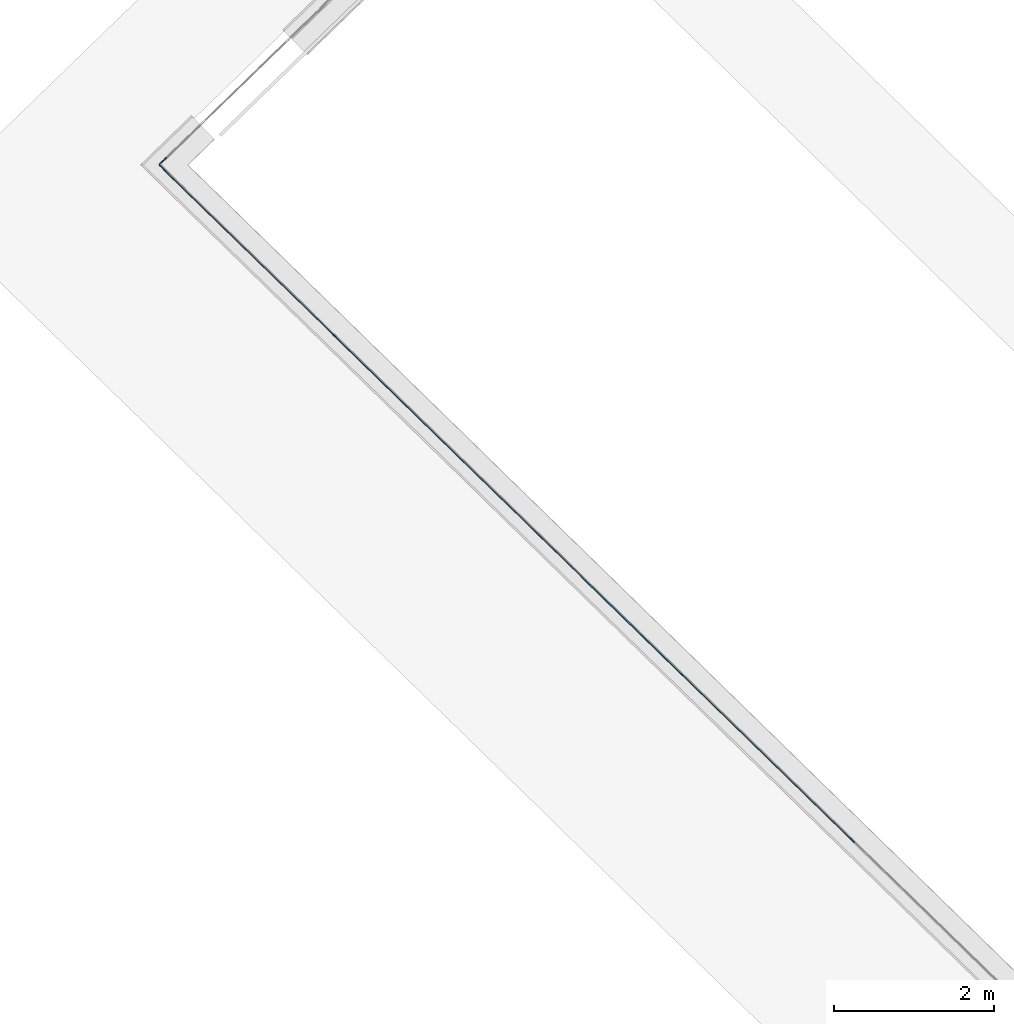
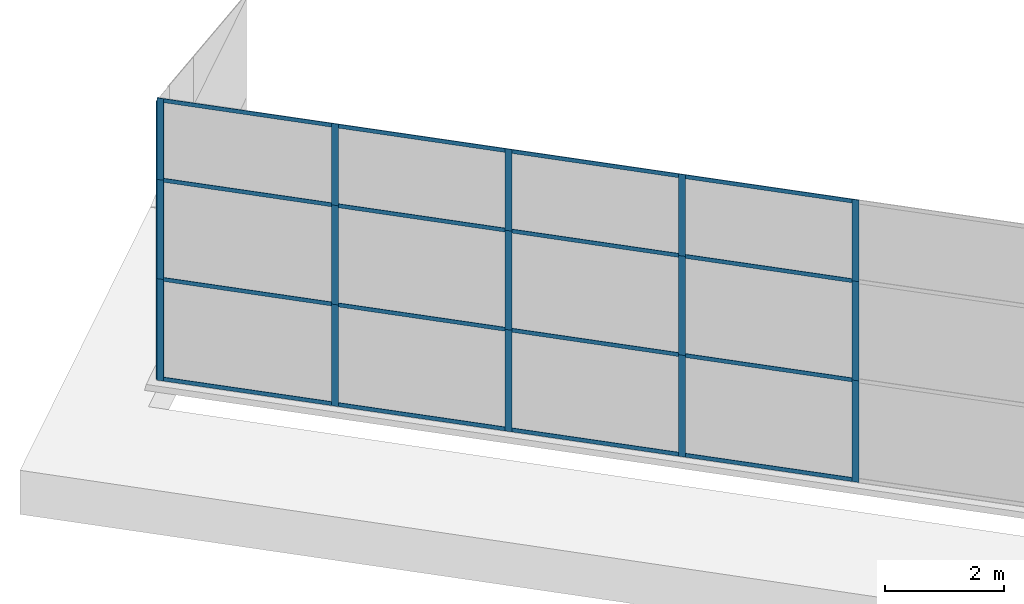
# One storey, part 5 of 13: 34 members, 2 elements without a shape of their own.
"""IFC4 building model written with IfcOpenShell, lengths in metres."""

from ifc_helpers import new_model, entity, si_unit, converted_unit, direction, frame, origin, place, context, subcontext, project, spatial, indexed_curve, outline, extrude, source, transform, mapped, material, type_object, type_shapes, element, aggregate, save


model = new_model("IFC4")

# Units and contexts
model_context = context("Model", 3, precision=1e-05, world=origin(), true_north=direction((6.123233995736766e-17, 1.0)))
body_context = subcontext(model_context, "Body", "Model", "MODEL_VIEW")
ifc_project = project(units=[si_unit("LENGTHUNIT", "METRE"), si_unit("AREAUNIT", "SQUARE_METRE"), si_unit("VOLUMEUNIT", "CUBIC_METRE"), converted_unit("PLANEANGLEUNIT", "DEGREE", entity("IfcPlaneAngleMeasure", 0.017453292519943278), si_unit("PLANEANGLEUNIT", "RADIAN"), dimensions=[0, 0, 0, 0, 0, 0, 0])], contexts=[model_context])

# Site, building, storey
site_placement = place(None, frame((0.0, 0.0, 0.0), z_axis=(0.0, 0.0, 1.0), x_axis=(0.7160934825303189, -0.6980043870045516, 0.0)))
site = spatial("IfcSite", under=ifc_project, at=site_placement, CompositionType="ELEMENT")
building_placement = place(site_placement, origin())
building = spatial("IfcBuilding", under=site, at=building_placement, CompositionType="ELEMENT")
storey_placement = place(building_placement, frame((0.0, 0.0, -7.0)))
storey = spatial("IfcBuildingStorey", under=building, at=storey_placement, Name="-7.00 m", CompositionType="ELEMENT", Elevation=-7.000000000000001)

# Curtain wall, members
curtain_wall_type_1 = type_object("IfcCurtainWallType", Name="Facciata continua:Vetrata_2", PredefinedType="NOTDEFINED")
curtain_wall_1_placement = place(storey_placement, frame((0.0, 0.0, 7.0)))
curtain_wall_1 = element("IfcCurtainWall", 1, at=curtain_wall_1_placement, inside=storey, type_object=curtain_wall_type_1, Name="Facciata continua:Vetrata_2", ObjectType="Facciata continua:Vetrata_2", PredefinedType="NOTDEFINED")
ifc_material = material(Name="Acciaio", Category="Metallo")
member_type_1 = type_object("IfcMemberType", Name="Montante rettangolare:Montante rettangolare 2", PredefinedType="MULLION", material=ifc_material)
shared_shape_1 = source(origin(), body_context, "Body", "SweptSolid", [
    extrude(outline(indexed_curve([(-0.04, -0.004999999999999997), (0.04, -0.004999999999999997), (0.04, 0.004999999999999997), (-0.04, 0.004999999999999997), (-0.04, -0.004999999999999997)], self_intersect=False)), frame((-0.04, 0.009999999999999993, -2.8811750164301526), z_axis=(0.0, 0.0, 1.0), x_axis=(-1.0, 0.0, 0.0)), (0.0, 0.0, 1.0), 2.881175016430152),
])
type_shapes(member_type_1, [shared_shape_1])
member_1_placement = place(curtain_wall_1_placement, frame((-21.789785339440044, -6.977854376535793, -1.1600000000000001), z_axis=(1.0, 0.0, 0.0), x_axis=(0.0, 0.0, 1.0)))
member_1 = element("IfcMember", 2, at=member_1_placement, type_object=member_type_1, material=ifc_material, Name="Montante rettangolare:Montante rettangolare 2", ObjectType="Montante rettangolare:Montante rettangolare 2", PredefinedType="MULLION", context=body_context, shape_type="MappedRepresentation", body=[
    mapped(shared_shape_1, transform((0.0, 0.0, 0.0), scale=1.0)),
])
member_2_placement = place(curtain_wall_1_placement, frame((-18.7886103230099, -6.977854376535803, -1.1600000000000001), z_axis=(1.0, 0.0, 0.0), x_axis=(0.0, 0.0, 1.0)))
member_2 = element("IfcMember", 3, at=member_2_placement, type_object=member_type_1, material=ifc_material, Name="Montante rettangolare:Montante rettangolare 2", ObjectType="Montante rettangolare:Montante rettangolare 2", PredefinedType="MULLION", context=body_context, shape_type="MappedRepresentation", body=[
    mapped(shared_shape_1, transform((0.0, 0.0, 0.0), scale=1.0)),
])
member_3_placement = place(curtain_wall_1_placement, frame((-15.787435306579756, -6.977854376535813, -1.1600000000000001), z_axis=(1.0, 0.0, 0.0), x_axis=(0.0, 0.0, 1.0)))
member_3 = element("IfcMember", 4, at=member_3_placement, type_object=member_type_1, material=ifc_material, Name="Montante rettangolare:Montante rettangolare 2", ObjectType="Montante rettangolare:Montante rettangolare 2", PredefinedType="MULLION", context=body_context, shape_type="MappedRepresentation", body=[
    mapped(shared_shape_1, transform((0.0, 0.0, 0.0), scale=1.0)),
])
member_type_2 = type_object("IfcMemberType", Name="Montante rettangolare:Montante rettangolare 2", PredefinedType="MULLION", material=ifc_material)
shared_shape_2 = source(origin(), body_context, "Body", "SweptSolid", [
    extrude(outline(indexed_curve([(-0.04, -0.004999999999999997), (0.04, -0.004999999999999997), (0.04, 0.004999999999999997), (-0.04, 0.004999999999999997), (-0.04, -0.004999999999999997)], self_intersect=False)), frame((-0.04, 0.009999999999999993, -2.9027458567862583), z_axis=(0.0, 0.0, 1.0), x_axis=(-1.0, 0.0, 0.0)), (0.0, 0.0, 1.0), 2.9027458567862583),
])
type_shapes(member_type_2, [shared_shape_2])
member_4_placement = place(curtain_wall_1_placement, frame((-24.79096035587019, -6.977854376535784, -1.1600000000000001), z_axis=(1.0, 0.0, 0.0), x_axis=(0.0, 0.0, 1.0)))
member_4 = element("IfcMember", 5, at=member_4_placement, type_object=member_type_2, material=ifc_material, Name="Montante rettangolare:Montante rettangolare 2", ObjectType="Montante rettangolare:Montante rettangolare 2", PredefinedType="MULLION", context=body_context, shape_type="MappedRepresentation", body=[
    mapped(shared_shape_2, transform((0.0, 0.0, 0.0), scale=1.0)),
])
member_type_3 = type_object("IfcMemberType", Name="Montante rettangolare:Montante rettangolare 2", PredefinedType="MULLION", material=ifc_material)
shared_shape_3 = source(origin(), body_context, "Body", "SweptSolid", [
    extrude(outline(indexed_curve([(-0.04, -0.004999999999999997), (0.04, -0.004999999999999997), (0.04, 0.004999999999999997), (-0.04, 0.004999999999999997), (-0.04, -0.004999999999999997)], self_intersect=False)), frame((-0.04, 0.009999999999999993, -2.9027458567862596), z_axis=(0.0, 0.0, 1.0), x_axis=(-1.0, 0.0, 0.0)), (0.0, 0.0, 1.0), 2.9027458567862583),
])
type_shapes(member_type_3, [shared_shape_3])
member_5_placement = place(curtain_wall_1_placement, frame((-27.693706212656448, -6.977854376535774, -6.94), z_axis=(-1.0, 0.0, 0.0), x_axis=(0.0, 0.0, -1.0)))
member_5 = element("IfcMember", 6, at=member_5_placement, type_object=member_type_3, material=ifc_material, Name="Montante rettangolare:Montante rettangolare 2", ObjectType="Montante rettangolare:Montante rettangolare 2", PredefinedType="MULLION", context=body_context, shape_type="MappedRepresentation", body=[
    mapped(shared_shape_3, transform((0.0, 0.0, 0.0), scale=1.0)),
])
member_type_4 = type_object("IfcMemberType", Name="Montante rettangolare:Montante rettangolare 2", PredefinedType="MULLION", material=ifc_material)
shared_shape_4 = source(origin(), body_context, "Body", "SweptSolid", [
    extrude(outline(indexed_curve([(-0.04, -0.004999999999999997), (0.04, -0.004999999999999997), (0.04, 0.004999999999999997), (-0.04, 0.004999999999999997), (-0.04, -0.004999999999999997)], self_intersect=False)), frame((-0.04, 0.009999999999999993, -2.8811750164301455), z_axis=(0.0, 0.0, 1.0), x_axis=(-1.0, 0.0, 0.0)), (0.0, 0.0, 1.0), 2.8811750164301437),
])
type_shapes(member_type_4, [shared_shape_4])
member_6_placement = place(curtain_wall_1_placement, frame((-24.67096035587019, -6.977854376535784, -6.94), z_axis=(-1.0, 0.0, 0.0), x_axis=(0.0, 0.0, -1.0)))
member_6 = element("IfcMember", 7, at=member_6_placement, type_object=member_type_4, material=ifc_material, Name="Montante rettangolare:Montante rettangolare 2", ObjectType="Montante rettangolare:Montante rettangolare 2", PredefinedType="MULLION", context=body_context, shape_type="MappedRepresentation", body=[
    mapped(shared_shape_4, transform((0.0, 0.0, 0.0), scale=1.0)),
])
member_7_placement = place(curtain_wall_1_placement, frame((-21.669785339440047, -6.977854376535793, -6.94), z_axis=(-1.0, 0.0, 0.0), x_axis=(0.0, 0.0, -1.0)))
member_7 = element("IfcMember", 8, at=member_7_placement, type_object=member_type_4, material=ifc_material, Name="Montante rettangolare:Montante rettangolare 2", ObjectType="Montante rettangolare:Montante rettangolare 2", PredefinedType="MULLION", context=body_context, shape_type="MappedRepresentation", body=[
    mapped(shared_shape_4, transform((0.0, 0.0, 0.0), scale=1.0)),
])
member_8_placement = place(curtain_wall_1_placement, frame((-18.668610323009904, -6.977854376535803, -6.94), z_axis=(-1.0, 0.0, 0.0), x_axis=(0.0, 0.0, -1.0)))
member_8 = element("IfcMember", 9, at=member_8_placement, type_object=member_type_4, material=ifc_material, Name="Montante rettangolare:Montante rettangolare 2", ObjectType="Montante rettangolare:Montante rettangolare 2", PredefinedType="MULLION", context=body_context, shape_type="MappedRepresentation", body=[
    mapped(shared_shape_4, transform((0.0, 0.0, 0.0), scale=1.0)),
])

curtain_wall_type_2 = type_object("IfcCurtainWallType", Name="Facciata continua:Vetrata_1", PredefinedType="NOTDEFINED")
curtain_wall_2_placement = place(storey_placement, frame((0.0, 0.0, 7.0)))
curtain_wall_2 = element("IfcCurtainWall", 10, at=curtain_wall_2_placement, inside=storey, type_object=curtain_wall_type_2, Name="Facciata continua:Vetrata_1", ObjectType="Facciata continua:Vetrata_1", PredefinedType="NOTDEFINED")
member_type_5 = type_object("IfcMemberType", Name="Montante rettangolare:Montante rettangolare 3", PredefinedType="MULLION", material=ifc_material)
shared_shape_5 = source(origin(), body_context, "Body", "SweptSolid", [
    extrude(outline(indexed_curve([(-0.06, -0.004999999999999997), (0.06, -0.004999999999999997), (0.06, 0.004999999999999997), (-0.06, 0.004999999999999997), (-0.06, -0.004999999999999997)], self_intersect=False)), frame((-0.06, 0.009999999999999993, -2.0800000000000005), z_axis=(0.0, 0.0, 1.0), x_axis=(-1.0, 0.0, 0.0)), (0.0, 0.0, 1.0), 2.0800000000000005),
])
type_shapes(member_type_5, [shared_shape_5])
member_9_placement = place(curtain_wall_2_placement, frame((-27.813706212656452, -6.977854376535775, -6.9399999999999995), z_axis=(0.0, 0.0, -1.0), x_axis=(-0.027980069795956325, -0.9996084812036228, 0.0)))
member_9 = element("IfcMember", 11, at=member_9_placement, type_object=member_type_5, material=ifc_material, Name="Montante rettangolare:Montante rettangolare 3", ObjectType="Montante rettangolare:Montante rettangolare 3", PredefinedType="MULLION", context=body_context, shape_type="MappedRepresentation", body=[
    mapped(shared_shape_5, transform((0.0, 0.0, 0.0), scale=1.0)),
])
member_type_6 = type_object("IfcMemberType", Name="Montante rettangolare:Montante rettangolare 3", PredefinedType="MULLION", material=ifc_material)
shared_shape_6 = source(origin(), body_context, "Body", "SweptSolid", [
    extrude(outline(indexed_curve([(-0.06, -0.004999999999999997), (0.06, -0.004999999999999997), (0.06, 0.004999999999999997), (-0.06, 0.004999999999999997), (-0.06, -0.004999999999999997)], self_intersect=False)), frame((-0.06, 0.009999999999999993, -2.030000000000001), z_axis=(0.0, 0.0, 1.0), x_axis=(-1.0, 0.0, 0.0)), (0.0, 0.0, 1.0), 2.030000000000001),
])
type_shapes(member_type_6, [shared_shape_6])
member_10_placement = place(curtain_wall_2_placement, frame((-27.813706212656452, -6.977854376535775, -4.86), z_axis=(0.0, 0.0, -1.0), x_axis=(-0.027980069795956325, -0.9996084812036228, 0.0)))
member_10 = element("IfcMember", 12, at=member_10_placement, type_object=member_type_6, material=ifc_material, Name="Montante rettangolare:Montante rettangolare 3", ObjectType="Montante rettangolare:Montante rettangolare 3", PredefinedType="MULLION", context=body_context, shape_type="MappedRepresentation", body=[
    mapped(shared_shape_6, transform((0.0, 0.0, 0.0), scale=1.0)),
])

# Member
member_type_7 = type_object("IfcMemberType", Name="Montante rettangolare:Montante rettangolare 3", PredefinedType="MULLION", material=ifc_material)
shared_shape_7 = source(origin(), body_context, "Body", "SweptSolid", [
    extrude(outline(indexed_curve([(-0.06, -0.004999999999999997), (0.06, -0.004999999999999997), (0.06, 0.004999999999999997), (-0.06, 0.004999999999999997), (-0.06, -0.004999999999999997)], self_intersect=False)), frame((-0.06, 0.009999999999999993, -1.6699999999999993), z_axis=(0.0, 0.0, 1.0), x_axis=(-1.0, 0.0, 0.0)), (0.0, 0.0, 1.0), 1.6699999999999993),
])
type_shapes(member_type_7, [shared_shape_7])
member_11_placement = place(curtain_wall_1_placement, frame((-27.81370621265645, -6.977854376535774, -1.1600000000000001), z_axis=(0.0, 0.0, 1.0), x_axis=(-1.0, 0.0, 0.0)))
member_11 = element("IfcMember", 13, at=member_11_placement, type_object=member_type_7, material=ifc_material, Name="Montante rettangolare:Montante rettangolare 3", ObjectType="Montante rettangolare:Montante rettangolare 3", PredefinedType="MULLION", context=body_context, shape_type="MappedRepresentation", body=[
    mapped(shared_shape_7, transform((0.0, 0.0, 0.0), scale=1.0)),
])

member_type_8 = type_object("IfcMemberType", Name="Montante rettangolare:Montante rettangolare 3", PredefinedType="MULLION", material=ifc_material)
shared_shape_8 = source(origin(), body_context, "Body", "SweptSolid", [
    extrude(outline(indexed_curve([(-0.06, -0.005000000000000005), (0.06, -0.005000000000000005), (0.06, 0.005000000000000005), (-0.06, 0.005000000000000005), (-0.06, -0.005000000000000005)], self_intersect=False)), frame((-0.06, 0.010000000000000002, -2.030000000000001), z_axis=(0.0, 0.0, 1.0), x_axis=(-1.0, 0.0, 0.0)), (0.0, 0.0, 1.0), 2.030000000000001),
])
type_shapes(member_type_8, [shared_shape_8])
member_12_placement = place(curtain_wall_1_placement, frame((-27.81370621265645, -6.977854376535774, -2.829999999999999), z_axis=(0.0, 0.0, 1.0), x_axis=(-1.0, 0.0, 0.0)))
member_12 = element("IfcMember", 14, at=member_12_placement, type_object=member_type_8, material=ifc_material, Name="Montante rettangolare:Montante rettangolare 3", ObjectType="Montante rettangolare:Montante rettangolare 3", PredefinedType="MULLION", context=body_context, shape_type="MappedRepresentation", body=[
    mapped(shared_shape_8, transform((0.0, 0.0, 0.0), scale=1.0)),
])

member_type_9 = type_object("IfcMemberType", Name="Montante rettangolare:Montante rettangolare 3", PredefinedType="MULLION", material=ifc_material)
shared_shape_9 = source(origin(), body_context, "Body", "SweptSolid", [
    extrude(outline(indexed_curve([(-0.06, -0.005000000000000005), (0.06, -0.005000000000000005), (0.06, 0.005000000000000005), (-0.06, 0.005000000000000005), (-0.06, -0.005000000000000005)], self_intersect=False)), frame((-0.06, 0.010000000000000002, -2.080000000000001), z_axis=(0.0, 0.0, 1.0), x_axis=(-1.0, 0.0, 0.0)), (0.0, 0.0, 1.0), 2.080000000000001),
])
type_shapes(member_type_9, [shared_shape_9])
member_13_placement = place(curtain_wall_1_placement, frame((-27.81370621265645, -6.977854376535774, -4.86), z_axis=(0.0, 0.0, 1.0), x_axis=(-1.0, 0.0, 0.0)))
member_13 = element("IfcMember", 15, at=member_13_placement, type_object=member_type_9, material=ifc_material, Name="Montante rettangolare:Montante rettangolare 3", ObjectType="Montante rettangolare:Montante rettangolare 3", PredefinedType="MULLION", context=body_context, shape_type="MappedRepresentation", body=[
    mapped(shared_shape_9, transform((0.0, 0.0, 0.0), scale=1.0)),
])

member_type_10 = type_object("IfcMemberType", Name="Montante rettangolare:Montante rettangolare 2", PredefinedType="MULLION", material=ifc_material)
shared_shape_10 = source(origin(), body_context, "Body", "SweptSolid", [
    extrude(outline(indexed_curve([(-0.04, -0.005000000000000001), (0.04, -0.005000000000000001), (0.04, 0.005000000000000001), (-0.04, 0.005000000000000001), (-0.04, -0.005000000000000001)], self_intersect=False)), frame((0.0, 0.009999999999999998, -2.9027458567862583), z_axis=(0.0, 0.0, 1.0), x_axis=(-1.0, 0.0, 0.0)), (0.0, 0.0, 1.0), 2.9027458567862583),
])
type_shapes(member_type_10, [shared_shape_10])
member_14_placement = place(curtain_wall_1_placement, frame((-24.79096035587019, -6.977854376535784, -2.829999999999999), z_axis=(1.0, 0.0, 0.0), x_axis=(0.0, 0.0, 1.0)))
member_14 = element("IfcMember", 16, at=member_14_placement, type_object=member_type_10, material=ifc_material, Name="Montante rettangolare:Montante rettangolare 2", ObjectType="Montante rettangolare:Montante rettangolare 2", PredefinedType="MULLION", context=body_context, shape_type="MappedRepresentation", body=[
    mapped(shared_shape_10, transform((0.0, 0.0, 0.0), scale=1.0)),
])

member_15_placement = place(curtain_wall_1_placement, frame((-24.79096035587019, -6.977854376535784, -4.86), z_axis=(1.0, 0.0, 0.0), x_axis=(0.0, 0.0, 1.0)))
member_15 = element("IfcMember", 17, at=member_15_placement, type_object=member_type_10, material=ifc_material, Name="Montante rettangolare:Montante rettangolare 2", ObjectType="Montante rettangolare:Montante rettangolare 2", PredefinedType="MULLION", context=body_context, shape_type="MappedRepresentation", body=[
    mapped(shared_shape_10, transform((0.0, 0.0, 0.0), scale=1.0)),
])

member_type_11 = type_object("IfcMemberType", Name="Montante rettangolare:Montante rettangolare 2", PredefinedType="MULLION", material=ifc_material)
shared_shape_11 = source(origin(), body_context, "Body", "SweptSolid", [
    extrude(outline(indexed_curve([(-0.04, -0.005000000000000001), (0.04, -0.005000000000000001), (0.04, 0.005000000000000001), (-0.04, 0.005000000000000001), (-0.04, -0.005000000000000001)], self_intersect=False)), frame((0.0, 0.009999999999999998, -2.8811750164301433), z_axis=(0.0, 0.0, 1.0), x_axis=(-1.0, 0.0, 0.0)), (0.0, 0.0, 1.0), 2.8811750164301437),
])
type_shapes(member_type_11, [shared_shape_11])
member_16_placement = place(curtain_wall_1_placement, frame((-21.789785339440044, -6.977854376535793, -2.829999999999999), z_axis=(1.0, 0.0, 0.0), x_axis=(0.0, 0.0, 1.0)))
member_16 = element("IfcMember", 18, at=member_16_placement, type_object=member_type_11, material=ifc_material, Name="Montante rettangolare:Montante rettangolare 2", ObjectType="Montante rettangolare:Montante rettangolare 2", PredefinedType="MULLION", context=body_context, shape_type="MappedRepresentation", body=[
    mapped(shared_shape_11, transform((0.0, 0.0, 0.0), scale=1.0)),
])

member_17_placement = place(curtain_wall_1_placement, frame((-18.7886103230099, -6.977854376535803, -2.829999999999999), z_axis=(1.0, 0.0, 0.0), x_axis=(0.0, 0.0, 1.0)))
member_17 = element("IfcMember", 19, at=member_17_placement, type_object=member_type_11, material=ifc_material, Name="Montante rettangolare:Montante rettangolare 2", ObjectType="Montante rettangolare:Montante rettangolare 2", PredefinedType="MULLION", context=body_context, shape_type="MappedRepresentation", body=[
    mapped(shared_shape_11, transform((0.0, 0.0, 0.0), scale=1.0)),
])

member_18_placement = place(curtain_wall_1_placement, frame((-15.787435306579757, -6.977854376535813, -2.829999999999999), z_axis=(1.0, 0.0, 0.0), x_axis=(0.0, 0.0, 1.0)))
member_18 = element("IfcMember", 20, at=member_18_placement, type_object=member_type_11, material=ifc_material, Name="Montante rettangolare:Montante rettangolare 2", ObjectType="Montante rettangolare:Montante rettangolare 2", PredefinedType="MULLION", context=body_context, shape_type="MappedRepresentation", body=[
    mapped(shared_shape_11, transform((0.0, 0.0, 0.0), scale=1.0)),
])

member_19_placement = place(curtain_wall_1_placement, frame((-21.789785339440044, -6.977854376535793, -4.86), z_axis=(1.0, 0.0, 0.0), x_axis=(0.0, 0.0, 1.0)))
member_19 = element("IfcMember", 21, at=member_19_placement, type_object=member_type_11, material=ifc_material, Name="Montante rettangolare:Montante rettangolare 2", ObjectType="Montante rettangolare:Montante rettangolare 2", PredefinedType="MULLION", context=body_context, shape_type="MappedRepresentation", body=[
    mapped(shared_shape_11, transform((0.0, 0.0, 0.0), scale=1.0)),
])

member_20_placement = place(curtain_wall_1_placement, frame((-18.7886103230099, -6.977854376535803, -4.86), z_axis=(1.0, 0.0, 0.0), x_axis=(0.0, 0.0, 1.0)))
member_20 = element("IfcMember", 22, at=member_20_placement, type_object=member_type_11, material=ifc_material, Name="Montante rettangolare:Montante rettangolare 2", ObjectType="Montante rettangolare:Montante rettangolare 2", PredefinedType="MULLION", context=body_context, shape_type="MappedRepresentation", body=[
    mapped(shared_shape_11, transform((0.0, 0.0, 0.0), scale=1.0)),
])

member_21_placement = place(curtain_wall_1_placement, frame((-15.787435306579757, -6.977854376535813, -4.86), z_axis=(1.0, 0.0, 0.0), x_axis=(0.0, 0.0, 1.0)))
member_21 = element("IfcMember", 23, at=member_21_placement, type_object=member_type_11, material=ifc_material, Name="Montante rettangolare:Montante rettangolare 2", ObjectType="Montante rettangolare:Montante rettangolare 2", PredefinedType="MULLION", context=body_context, shape_type="MappedRepresentation", body=[
    mapped(shared_shape_11, transform((0.0, 0.0, 0.0), scale=1.0)),
])

member_type_12 = type_object("IfcMemberType", Name="Montante rettangolare:Montante rettangolare 3", PredefinedType="MULLION", material=ifc_material)
shared_shape_12 = source(origin(), body_context, "Body", "SweptSolid", [
    extrude(outline(indexed_curve([(-0.06, -0.005000000000000001), (0.06, -0.005000000000000001), (0.06, 0.005000000000000001), (-0.06, 0.005000000000000001), (-0.06, -0.005000000000000001)], self_intersect=False)), frame((0.0, 0.009999999999999998, -2.0800000000000005), z_axis=(0.0, 0.0, 1.0), x_axis=(-1.0, 0.0, 0.0)), (0.0, 0.0, 1.0), 2.0800000000000005),
])
type_shapes(member_type_12, [shared_shape_12])
member_22_placement = place(curtain_wall_1_placement, frame((-24.730960355870188, -6.977854376535784, -6.94), z_axis=(0.0, 0.0, -1.0), x_axis=(1.0, 0.0, 0.0)))
member_22 = element("IfcMember", 24, at=member_22_placement, type_object=member_type_12, material=ifc_material, Name="Montante rettangolare:Montante rettangolare 3", ObjectType="Montante rettangolare:Montante rettangolare 3", PredefinedType="MULLION", context=body_context, shape_type="MappedRepresentation", body=[
    mapped(shared_shape_12, transform((0.0, 0.0, 0.0), scale=1.0)),
])

member_23_placement = place(curtain_wall_1_placement, frame((-21.729785339440046, -6.977854376535793, -6.94), z_axis=(0.0, 0.0, -1.0), x_axis=(1.0, 0.0, 0.0)))
member_23 = element("IfcMember", 25, at=member_23_placement, type_object=member_type_12, material=ifc_material, Name="Montante rettangolare:Montante rettangolare 3", ObjectType="Montante rettangolare:Montante rettangolare 3", PredefinedType="MULLION", context=body_context, shape_type="MappedRepresentation", body=[
    mapped(shared_shape_12, transform((0.0, 0.0, 0.0), scale=1.0)),
])

member_24_placement = place(curtain_wall_1_placement, frame((-18.728610323009903, -6.977854376535803, -6.94), z_axis=(0.0, 0.0, -1.0), x_axis=(1.0, 0.0, 0.0)))
member_24 = element("IfcMember", 26, at=member_24_placement, type_object=member_type_12, material=ifc_material, Name="Montante rettangolare:Montante rettangolare 3", ObjectType="Montante rettangolare:Montante rettangolare 3", PredefinedType="MULLION", context=body_context, shape_type="MappedRepresentation", body=[
    mapped(shared_shape_12, transform((0.0, 0.0, 0.0), scale=1.0)),
])

member_25_placement = place(curtain_wall_1_placement, frame((-15.72743530657976, -6.977854376535813, -6.94), z_axis=(0.0, 0.0, -1.0), x_axis=(1.0, 0.0, 0.0)))
member_25 = element("IfcMember", 27, at=member_25_placement, type_object=member_type_12, material=ifc_material, Name="Montante rettangolare:Montante rettangolare 3", ObjectType="Montante rettangolare:Montante rettangolare 3", PredefinedType="MULLION", context=body_context, shape_type="MappedRepresentation", body=[
    mapped(shared_shape_12, transform((0.0, 0.0, 0.0), scale=1.0)),
])

member_type_13 = type_object("IfcMemberType", Name="Montante rettangolare:Montante rettangolare 3", PredefinedType="MULLION", material=ifc_material)
shared_shape_13 = source(origin(), body_context, "Body", "SweptSolid", [
    extrude(outline(indexed_curve([(-0.06, -0.005000000000000001), (0.06, -0.005000000000000001), (0.06, 0.005000000000000001), (-0.06, 0.005000000000000001), (-0.06, -0.005000000000000001)], self_intersect=False)), frame((0.0, 0.009999999999999998, -1.6699999999999993), z_axis=(0.0, 0.0, 1.0), x_axis=(-1.0, 0.0, 0.0)), (0.0, 0.0, 1.0), 1.6699999999999993),
])
type_shapes(member_type_13, [shared_shape_13])
member_26_placement = place(curtain_wall_1_placement, frame((-24.730960355870188, -6.977854376535784, -2.829999999999999), z_axis=(0.0, 0.0, -1.0), x_axis=(1.0, 0.0, 0.0)))
member_26 = element("IfcMember", 28, at=member_26_placement, type_object=member_type_13, material=ifc_material, Name="Montante rettangolare:Montante rettangolare 3", ObjectType="Montante rettangolare:Montante rettangolare 3", PredefinedType="MULLION", context=body_context, shape_type="MappedRepresentation", body=[
    mapped(shared_shape_13, transform((0.0, 0.0, 0.0), scale=1.0)),
])

member_27_placement = place(curtain_wall_1_placement, frame((-21.729785339440046, -6.977854376535793, -2.829999999999999), z_axis=(0.0, 0.0, -1.0), x_axis=(1.0, 0.0, 0.0)))
member_27 = element("IfcMember", 29, at=member_27_placement, type_object=member_type_13, material=ifc_material, Name="Montante rettangolare:Montante rettangolare 3", ObjectType="Montante rettangolare:Montante rettangolare 3", PredefinedType="MULLION", context=body_context, shape_type="MappedRepresentation", body=[
    mapped(shared_shape_13, transform((0.0, 0.0, 0.0), scale=1.0)),
])

member_28_placement = place(curtain_wall_1_placement, frame((-18.728610323009903, -6.977854376535803, -2.829999999999999), z_axis=(0.0, 0.0, -1.0), x_axis=(1.0, 0.0, 0.0)))
member_28 = element("IfcMember", 30, at=member_28_placement, type_object=member_type_13, material=ifc_material, Name="Montante rettangolare:Montante rettangolare 3", ObjectType="Montante rettangolare:Montante rettangolare 3", PredefinedType="MULLION", context=body_context, shape_type="MappedRepresentation", body=[
    mapped(shared_shape_13, transform((0.0, 0.0, 0.0), scale=1.0)),
])

member_29_placement = place(curtain_wall_1_placement, frame((-15.727435306579759, -6.977854376535813, -2.829999999999999), z_axis=(0.0, 0.0, -1.0), x_axis=(1.0, 0.0, 0.0)))
member_29 = element("IfcMember", 31, at=member_29_placement, type_object=member_type_13, material=ifc_material, Name="Montante rettangolare:Montante rettangolare 3", ObjectType="Montante rettangolare:Montante rettangolare 3", PredefinedType="MULLION", context=body_context, shape_type="MappedRepresentation", body=[
    mapped(shared_shape_13, transform((0.0, 0.0, 0.0), scale=1.0)),
])

member_type_14 = type_object("IfcMemberType", Name="Montante rettangolare:Montante rettangolare 3", PredefinedType="MULLION", material=ifc_material)
shared_shape_14 = source(origin(), body_context, "Body", "SweptSolid", [
    extrude(outline(indexed_curve([(-0.06, -0.005000000000000001), (0.06, -0.005000000000000001), (0.06, 0.005000000000000001), (-0.06, 0.005000000000000001), (-0.06, -0.005000000000000001)], self_intersect=False)), frame((0.0, 0.009999999999999998, -2.030000000000001), z_axis=(0.0, 0.0, 1.0), x_axis=(-1.0, 0.0, 0.0)), (0.0, 0.0, 1.0), 2.030000000000001),
])
type_shapes(member_type_14, [shared_shape_14])
member_30_placement = place(curtain_wall_1_placement, frame((-24.730960355870188, -6.977854376535784, -4.86), z_axis=(0.0, 0.0, -1.0), x_axis=(1.0, 0.0, 0.0)))
member_30 = element("IfcMember", 32, at=member_30_placement, type_object=member_type_14, material=ifc_material, Name="Montante rettangolare:Montante rettangolare 3", ObjectType="Montante rettangolare:Montante rettangolare 3", PredefinedType="MULLION", context=body_context, shape_type="MappedRepresentation", body=[
    mapped(shared_shape_14, transform((0.0, 0.0, 0.0), scale=1.0)),
])

member_31_placement = place(curtain_wall_1_placement, frame((-21.729785339440046, -6.977854376535793, -4.86), z_axis=(0.0, 0.0, -1.0), x_axis=(1.0, 0.0, 0.0)))
member_31 = element("IfcMember", 33, at=member_31_placement, type_object=member_type_14, material=ifc_material, Name="Montante rettangolare:Montante rettangolare 3", ObjectType="Montante rettangolare:Montante rettangolare 3", PredefinedType="MULLION", context=body_context, shape_type="MappedRepresentation", body=[
    mapped(shared_shape_14, transform((0.0, 0.0, 0.0), scale=1.0)),
])

member_32_placement = place(curtain_wall_1_placement, frame((-18.728610323009903, -6.977854376535803, -4.86), z_axis=(0.0, 0.0, -1.0), x_axis=(1.0, 0.0, 0.0)))
member_32 = element("IfcMember", 34, at=member_32_placement, type_object=member_type_14, material=ifc_material, Name="Montante rettangolare:Montante rettangolare 3", ObjectType="Montante rettangolare:Montante rettangolare 3", PredefinedType="MULLION", context=body_context, shape_type="MappedRepresentation", body=[
    mapped(shared_shape_14, transform((0.0, 0.0, 0.0), scale=1.0)),
])

member_33_placement = place(curtain_wall_1_placement, frame((-15.727435306579759, -6.977854376535813, -4.86), z_axis=(0.0, 0.0, -1.0), x_axis=(1.0, 0.0, 0.0)))
member_33 = element("IfcMember", 35, at=member_33_placement, type_object=member_type_14, material=ifc_material, Name="Montante rettangolare:Montante rettangolare 3", ObjectType="Montante rettangolare:Montante rettangolare 3", PredefinedType="MULLION", context=body_context, shape_type="MappedRepresentation", body=[
    mapped(shared_shape_14, transform((0.0, 0.0, 0.0), scale=1.0)),
])

aggregate(curtain_wall_1, [member_4, member_1, member_2, member_3, member_5, member_6, member_7, member_8, member_11, member_12, member_13, member_14, member_16, member_17, member_18, member_15, member_19, member_20, member_21, member_22, member_23, member_24, member_25, member_26, member_27, member_28, member_29, member_30, member_31, member_32, member_33])

member_type_15 = type_object("IfcMemberType", Name="Montante rettangolare:Montante rettangolare 3", PredefinedType="MULLION", material=ifc_material)
shared_shape_15 = source(origin(), body_context, "Body", "SweptSolid", [
    extrude(outline(indexed_curve([(-0.06, -0.004999999999999997), (0.06, -0.004999999999999997), (0.06, 0.004999999999999997), (-0.06, 0.004999999999999997), (-0.06, -0.004999999999999997)], self_intersect=False)), frame((-0.06, 0.009999999999999993, -1.5900000000000003), z_axis=(0.0, 0.0, 1.0), x_axis=(-1.0, 0.0, 0.0)), (0.0, 0.0, 1.0), 1.5900000000000003),
])
type_shapes(member_type_15, [shared_shape_15])
member_34_placement = place(curtain_wall_2_placement, frame((-27.813706212656452, -6.977854376535775, -2.829999999999999), z_axis=(0.0, 0.0, -1.0), x_axis=(-0.027980069795956325, -0.9996084812036228, 0.0)))
member_34 = element("IfcMember", 36, at=member_34_placement, type_object=member_type_15, material=ifc_material, Name="Montante rettangolare:Montante rettangolare 3", ObjectType="Montante rettangolare:Montante rettangolare 3", PredefinedType="MULLION", context=body_context, shape_type="MappedRepresentation", body=[
    mapped(shared_shape_15, transform((0.0, 0.0, 0.0), scale=1.0)),
])

aggregate(curtain_wall_2, [member_9, member_34, member_10])

save(model, "model.ifc")
